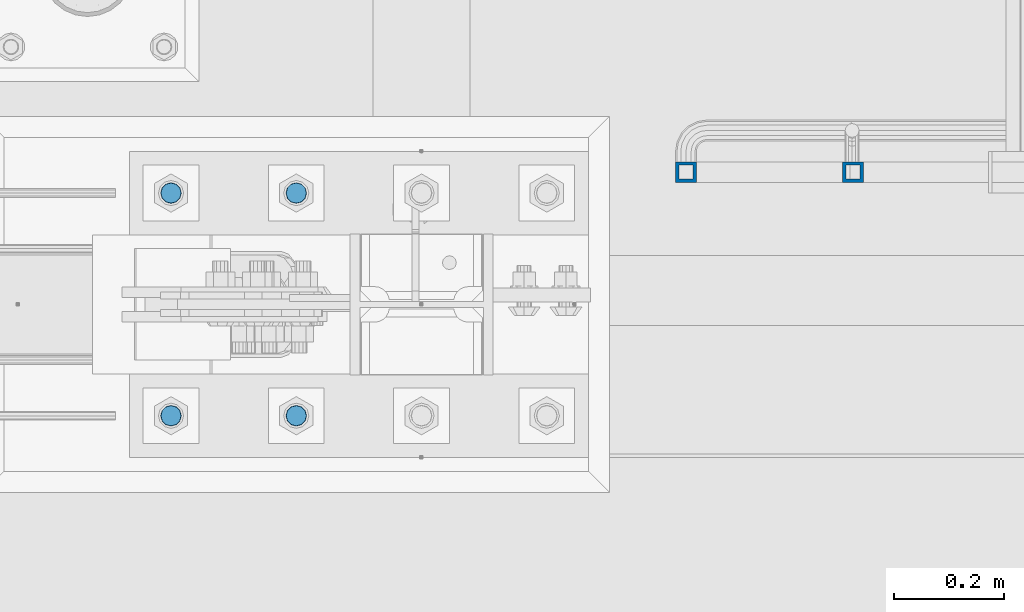
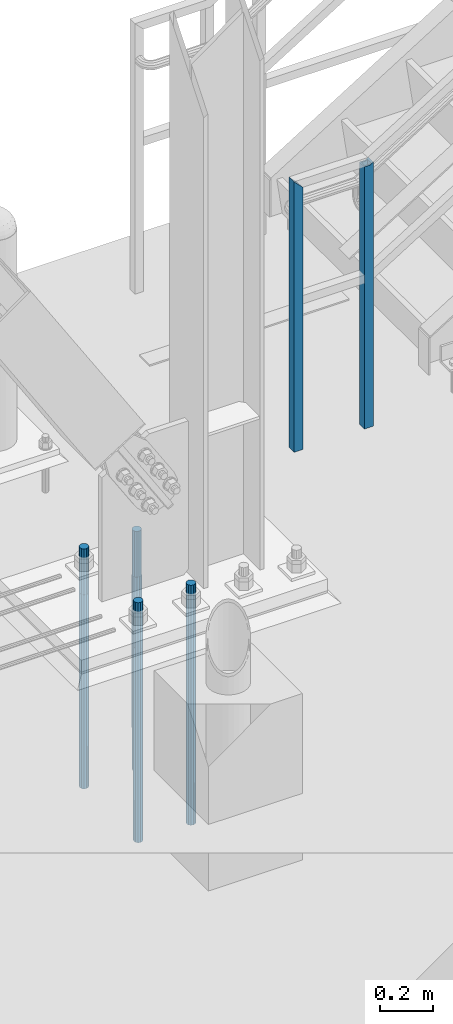
# One storey, part 1365 of 3843: 6 columns, 2 elements without a shape of their own.
"""IFC2X3 building model written with IfcOpenShell, lengths in millimetres."""

from ifc_helpers import new_model, si_unit, frame, origin_with_axes, place, context, subcontext, project, spatial, faceted_brep, material, type_object, element, aggregate, save


model = new_model("IFC2X3")

# Units and contexts
model_context = context("Model", 3, precision=1e-05, world=origin_with_axes())
body_context = subcontext(model_context, "Body", "Model", "MODEL_VIEW")
ifc_project = project(units=[si_unit("LENGTHUNIT", "METRE", prefix="MILLI"), si_unit("AREAUNIT", "SQUARE_METRE"), si_unit("VOLUMEUNIT", "CUBIC_METRE"), si_unit("MASSUNIT", "GRAM", prefix="KILO"), si_unit("TIMEUNIT", "SECOND"), si_unit("PLANEANGLEUNIT", "RADIAN"), si_unit("SOLIDANGLEUNIT", "STERADIAN"), si_unit("THERMODYNAMICTEMPERATUREUNIT", "DEGREE_CELSIUS"), si_unit("LUMINOUSINTENSITYUNIT", "LUMEN")], contexts=[model_context])

# Site, building, storey
site_placement = place(None, origin_with_axes())
site = spatial("IfcSite", under=ifc_project, at=site_placement, CompositionType="ELEMENT")
building_placement = place(site_placement, origin_with_axes())
building = spatial("IfcBuilding", under=site, at=building_placement, Name="Undefined", CompositionType="ELEMENT")
storey_placement = place(building_placement, origin_with_axes())
storey = spatial("IfcBuildingStorey", under=building, at=storey_placement, Name="Undefined", CompositionType="ELEMENT", Elevation=0.0)

# Assembly, columns
assembly_1_placement = place(storey_placement, origin_with_axes())
assembly_1 = element("IfcElementAssembly", 1, at=assembly_1_placement, inside=storey, Name="RAIL", AssemblyPlace="NOTDEFINED", PredefinedType="RIGID_FRAME")
ifc_material_1 = material()
column_type_1 = type_object("IfcColumnType", Name="HSS1-1/2X1-1/2X1/4", PredefinedType="NOTDEFINED")
column_1_placement = place(assembly_1_placement, frame((31267.4000000001, 89357.2000000455, 30480.0), z_axis=(-1.0, 0.0, 0.0), x_axis=(0.0, 0.0, 1.0)))
column_1 = element("IfcColumn", 2, at=column_1_placement, type_object=column_type_1, material=ifc_material_1, Name="POST", ObjectType="HSS1-1/2X1-1/2X1/4", context=body_context, shape_type="Brep", body=[
    faceted_brep([(1047.75000076629, -19.0499992350015, 19.0499992349942), (1047.75000076347, -19.0499992349796, -5.45142732938621), (1047.75000076347, -12.6999993299978, -5.45142732938621), (1047.75000076497, -12.6999993300014, 12.6999993299978), (1047.75000076497, 12.6999993300014, 12.6999993299978), (1047.75000076347, 12.6999993299978, -5.45142732938621), (1047.75000076347, 19.0499992350233, -5.45142732938621), (1047.75000076629, 19.0499992350015, 19.0499992349942), (1056.22703259967, -19.0499992349651, -19.0499992350015), (1056.22703259967, 19.0499992349942, -19.0499992350015), (1052.26859110094, 12.6999993299978, -12.6999993300014), (1052.26859110094, -12.6999993299978, -12.6999993300014), (-152.399999977541, 19.0499992350015, 19.0499992349942), (-152.399999977541, -19.0499992350015, 19.0499992349942), (-152.399999977541, -19.0499992350015, -19.0499992349942), (-152.399999977541, 19.0499992350015, -19.0499992349942), (-152.399999977541, 12.6999993299978, 12.6999993299978), (-152.399999977541, -12.6999993299978, 12.6999993299978), (-152.399999977541, -12.6999993299978, -12.6999993299978), (-152.399999977541, 12.6999993299978, -12.6999993299978)], [[[0, 1, 2, 3, 4, 5, 6, 7]], [[8, 9, 6, 5, 10, 11, 2, 1]], [[12, 13, 0, 7]], [[0, 13, 14, 8, 1]], [[14, 15, 9, 8]], [[15, 12, 7, 6, 9]], [[14, 13, 12, 15], [16, 17, 18, 19]], [[19, 18, 11, 10]], [[4, 16, 19, 10, 5]], [[17, 16, 4, 3]], [[18, 17, 3, 2, 11]]]),
])
column_2_placement = place(assembly_1_placement, frame((30962.6000000001, 89357.2000000455, 30480.0), z_axis=(-1.0, 0.0, 0.0), x_axis=(0.0, 0.0, 1.0)))
column_2 = element("IfcColumn", 3, at=column_2_placement, type_object=column_type_1, material=ifc_material_1, Name="POST", ObjectType="HSS1-1/2X1-1/2X1/4", context=body_context, shape_type="Brep", body=[
    faceted_brep([(-152.399999977541, 12.6999993299978, -12.6999993299978), (-152.399999977541, -12.6999993299978, -12.6999993299978), (1054.10000067001, -12.6999993300014, -12.6999993299978), (1054.10000067001, 12.6999993300014, -12.6999993299978), (-152.399999977541, -12.6999993299978, 12.6999993299978), (1079.49999933, -12.6999993300014, 12.6999993299978), (-152.399999977541, 12.6999993299978, 12.6999993299978), (1079.49999933, 12.6999993300014, 12.6999993299978), (-152.399999977541, 19.0499992350015, -19.0499992349942), (-152.399999977541, 19.0499992350015, 19.0499992349942), (1085.849999235, 19.0499992350015, 19.0499992350015), (1047.750000765, 19.0499992350015, -19.0499992350015), (-152.399999977541, -19.0499992350015, 19.0499992349942), (1085.849999235, -19.0499992350015, 19.0499992350015), (-152.399999977541, -19.0499992350015, -19.0499992349942), (1047.750000765, -19.0499992350015, -19.0499992350015)], [[[0, 1, 2, 3]], [[1, 4, 5, 2]], [[4, 6, 7, 5]], [[6, 0, 3, 7]], [[8, 9, 10, 11]], [[9, 12, 13, 10]], [[12, 14, 15, 13]], [[14, 8, 11, 15]], [[13, 15, 11, 10], [5, 7, 3, 2]], [[14, 12, 9, 8], [6, 4, 1, 0]]]),
])
aggregate(assembly_1, [column_1, column_2])

assembly_2_placement = place(storey_placement, origin_with_axes())
assembly_2 = element("IfcElementAssembly", 4, at=assembly_2_placement, inside=storey, Name="TEMPLATE", AssemblyPlace="NOTDEFINED", PredefinedType="RIGID_FRAME")
ifc_material_2 = material(Name="Undefined/F1554-GR.55")
column_type_2 = type_object("IfcColumnType", PredefinedType="NOTDEFINED")
column_3_placement = place(assembly_2_placement, frame((30251.4, 88912.7, 30022.8), z_axis=(1.0, 0.0, 0.0), x_axis=(0.0, 0.0, -1.0)))
column_3 = element("IfcColumn", 5, at=column_3_placement, type_object=column_type_2, material=ifc_material_2, Name="ANCHOR_ROD", context=body_context, shape_type="Brep", body=[
    faceted_brep([(-209.549999999999, -16.0214699700155, 9.25), (-209.549999999999, -9.25, 16.0214699700118), (-209.549999999999, 0.0, 18.5), (-209.549999999999, 9.25, 16.0214699700118), (-209.549999999999, 16.0214699700155, 9.25), (-209.549999999999, 18.5, 0.0), (-209.549999999999, 16.0214699700155, -9.25), (-209.549999999999, 9.25, -16.0214699700118), (-209.549999999999, 0.0, -18.5), (-209.549999999999, -9.25, -16.0214699700118), (-209.549999999999, -16.0214699700155, -9.25), (-209.549999999999, -18.5, 0.0), (0.0, 18.5, 0.0), (0.0, 16.0214699700118, -9.25), (0.0, 9.25, -16.0214699700155), (0.0, 0.0, -18.5), (0.0, -9.25, -16.0214699700155), (0.0, -16.0214699700118, -9.25), (0.0, -18.5, 0.0), (0.0, -16.0214699700118, 9.25), (0.0, -9.25, 16.0214699700155), (0.0, 0.0, 18.5), (0.0, 9.25, 16.0214699700155), (0.0, 16.0214699700118, 9.25), (0.0, -16.4977839420972, 9.52500000000146), (0.0, -9.52500000000146, 16.4977839420972), (0.0, 0.0, 19.0499989999989), (0.0, 9.52500000000146, 16.4977839420972), (0.0, 16.4977839420972, 9.52500000000146), (0.0, 19.0500000000029, 0.0), (0.0, 16.4977839420972, -9.52500000000146), (0.0, 9.52500000000146, -16.4977839420972), (0.0, 0.0, -19.0499989999989), (0.0, -9.52500000000146, -16.4977839420972), (0.0, -16.4977839420972, -9.52500000000146), (0.0, -19.0500000000029, 0.0), (698.5, -19.0499999999993, 0.0), (698.5, -16.4977839420935, 9.52499999999418), (698.5, -9.52500000000146, 16.4977839420899), (698.5, 0.0, 19.0500000000029), (698.5, 9.52500000000146, 16.4977839420899), (698.5, 16.4977839420935, 9.52499999999418), (698.5, 19.0499999999993, 0.0), (698.5, 16.4977839420935, -9.52499999999418), (698.5, 9.52500000000146, -16.4977839420899), (698.5, 0.0, -19.0500000000029), (698.5, -9.52500000000146, -16.4977839420899), (698.5, -16.4977839420935, -9.52499999999418), (698.5, -9.25, 16.0214699700155), (698.5, 0.0, 18.5), (698.5, 9.25, 16.0214699700155), (698.5, 16.0214699700118, 9.25), (698.5, 18.5, 0.0), (698.5, 16.0214699700118, -9.25), (698.5, 9.25, -16.0214699700155), (698.5, 0.0, -18.5), (698.5, -9.25, -16.0214699700155), (698.5, -16.0214699700118, -9.25), (698.5, -18.5, 0.0), (698.5, -16.0214699700118, 9.25), (889.0, -9.25, -16.0214699700155), (889.0, 0.0, -18.5), (889.0, 9.25, -16.0214699700155), (889.0, 16.0214699700118, -9.25), (889.0, 18.5, 0.0), (889.0, 16.0214699700118, 9.25), (889.0, 9.25, 16.0214699700155), (889.0, 0.0, 18.5), (889.0, -9.25, 16.0214699700155), (889.0, -16.0214699700118, 9.25), (889.0, -18.5, 0.0), (889.0, -16.0214699700118, -9.25)], [[[0, 1, 2, 3, 4, 5, 6, 7, 8, 9, 10, 11]], [[6, 5, 12, 13]], [[7, 6, 13, 14]], [[8, 7, 14, 15]], [[9, 8, 15, 16]], [[10, 9, 16, 17]], [[11, 10, 17, 18]], [[0, 11, 18, 19]], [[1, 0, 19, 20]], [[2, 1, 20, 21]], [[3, 2, 21, 22]], [[4, 3, 22, 23]], [[5, 4, 23, 12]], [[24, 25, 26, 27, 28, 29, 30, 31, 32, 33, 34, 35], [22, 21, 20, 19, 18, 17, 16, 15, 14, 13, 12, 23]], [[24, 35, 36, 37]], [[25, 24, 37, 38]], [[26, 25, 38, 39]], [[27, 26, 39, 40]], [[28, 27, 40, 41]], [[29, 28, 41, 42]], [[30, 29, 42, 43]], [[31, 30, 43, 44]], [[32, 31, 44, 45]], [[33, 32, 45, 46]], [[34, 33, 46, 47]], [[35, 34, 47, 36]], [[46, 45, 44, 43, 42, 41, 40, 39, 38, 37, 36, 47], [48, 49, 50, 51, 52, 53, 54, 55, 56, 57, 58, 59]], [[60, 61, 62, 63, 64, 65, 66, 67, 68, 69, 70, 71]], [[68, 67, 49, 48]], [[69, 68, 48, 59]], [[70, 69, 59, 58]], [[71, 70, 58, 57]], [[60, 71, 57, 56]], [[61, 60, 56, 55]], [[62, 61, 55, 54]], [[63, 62, 54, 53]], [[64, 63, 53, 52]], [[65, 64, 52, 51]], [[66, 65, 51, 50]], [[67, 66, 50, 49]]]),
])
column_4_placement = place(assembly_2_placement, frame((30251.4, 89319.1, 30022.8), z_axis=(-1.0, 0.0, 0.0), x_axis=(0.0, 0.0, -1.0)))
column_4 = element("IfcColumn", 6, at=column_4_placement, type_object=column_type_2, material=ifc_material_2, Name="ANCHOR_ROD", context=body_context, shape_type="Brep", body=[
    faceted_brep([(-209.549999999999, -16.0214699700155, 9.25), (-209.549999999999, -9.25, 16.0214699700118), (-209.549999999999, 0.0, 18.5), (-209.549999999999, 9.25, 16.0214699700118), (-209.549999999999, 16.0214699700155, 9.25), (-209.549999999999, 18.5, 0.0), (-209.549999999999, 16.0214699700155, -9.25), (-209.549999999999, 9.25, -16.0214699700118), (-209.549999999999, 0.0, -18.5), (-209.549999999999, -9.25, -16.0214699700118), (-209.549999999999, -16.0214699700155, -9.25), (-209.549999999999, -18.5, 0.0), (0.0, 18.5, 0.0), (0.0, 16.0214699700118, -9.25), (0.0, 9.25, -16.0214699700155), (0.0, 0.0, -18.5), (0.0, -9.25, -16.0214699700155), (0.0, -16.0214699700118, -9.25), (0.0, -18.5, 0.0), (0.0, -16.0214699700118, 9.25), (0.0, -9.25, 16.0214699700155), (0.0, 0.0, 18.5), (0.0, 9.25, 16.0214699700155), (0.0, 16.0214699700118, 9.25), (0.0, -16.4977839420972, 9.52500000000146), (0.0, -9.52500000000146, 16.4977839420972), (0.0, 0.0, 19.0499989999989), (0.0, 9.52500000000146, 16.4977839420972), (0.0, 16.4977839420972, 9.52500000000146), (0.0, 19.0500000000029, 0.0), (0.0, 16.4977839420972, -9.52500000000146), (0.0, 9.52500000000146, -16.4977839420972), (0.0, 0.0, -19.0499989999989), (0.0, -9.52500000000146, -16.4977839420972), (0.0, -16.4977839420972, -9.52500000000146), (0.0, -19.0500000000029, 0.0), (698.5, -19.0499999999993, 0.0), (698.5, -16.4977839420935, 9.52499999999418), (698.5, -9.52500000000146, 16.4977839420899), (698.5, 0.0, 19.0500000000029), (698.5, 9.52500000000146, 16.4977839420899), (698.5, 16.4977839420935, 9.52499999999418), (698.5, 19.0499999999993, 0.0), (698.5, 16.4977839420935, -9.52499999999418), (698.5, 9.52500000000146, -16.4977839420899), (698.5, 0.0, -19.0500000000029), (698.5, -9.52500000000146, -16.4977839420899), (698.5, -16.4977839420935, -9.52499999999418), (698.5, -9.25, 16.0214699700155), (698.5, 0.0, 18.5), (698.5, 9.25, 16.0214699700155), (698.5, 16.0214699700118, 9.25), (698.5, 18.5, 0.0), (698.5, 16.0214699700118, -9.25), (698.5, 9.25, -16.0214699700155), (698.5, 0.0, -18.5), (698.5, -9.25, -16.0214699700155), (698.5, -16.0214699700118, -9.25), (698.5, -18.5, 0.0), (698.5, -16.0214699700118, 9.25), (889.0, -9.25, -16.0214699700155), (889.0, 0.0, -18.5), (889.0, 9.25, -16.0214699700155), (889.0, 16.0214699700118, -9.25), (889.0, 18.5, 0.0), (889.0, 16.0214699700118, 9.25), (889.0, 9.25, 16.0214699700155), (889.0, 0.0, 18.5), (889.0, -9.25, 16.0214699700155), (889.0, -16.0214699700118, 9.25), (889.0, -18.5, 0.0), (889.0, -16.0214699700118, -9.25)], [[[0, 1, 2, 3, 4, 5, 6, 7, 8, 9, 10, 11]], [[6, 5, 12, 13]], [[7, 6, 13, 14]], [[8, 7, 14, 15]], [[9, 8, 15, 16]], [[10, 9, 16, 17]], [[11, 10, 17, 18]], [[0, 11, 18, 19]], [[1, 0, 19, 20]], [[2, 1, 20, 21]], [[3, 2, 21, 22]], [[4, 3, 22, 23]], [[5, 4, 23, 12]], [[24, 25, 26, 27, 28, 29, 30, 31, 32, 33, 34, 35], [22, 21, 20, 19, 18, 17, 16, 15, 14, 13, 12, 23]], [[24, 35, 36, 37]], [[25, 24, 37, 38]], [[26, 25, 38, 39]], [[27, 26, 39, 40]], [[28, 27, 40, 41]], [[29, 28, 41, 42]], [[30, 29, 42, 43]], [[31, 30, 43, 44]], [[32, 31, 44, 45]], [[33, 32, 45, 46]], [[34, 33, 46, 47]], [[35, 34, 47, 36]], [[46, 45, 44, 43, 42, 41, 40, 39, 38, 37, 36, 47], [48, 49, 50, 51, 52, 53, 54, 55, 56, 57, 58, 59]], [[60, 61, 62, 63, 64, 65, 66, 67, 68, 69, 70, 71]], [[68, 67, 49, 48]], [[69, 68, 48, 59]], [[70, 69, 59, 58]], [[71, 70, 58, 57]], [[60, 71, 57, 56]], [[61, 60, 56, 55]], [[62, 61, 55, 54]], [[63, 62, 54, 53]], [[64, 63, 53, 52]], [[65, 64, 52, 51]], [[66, 65, 51, 50]], [[67, 66, 50, 49]]]),
])
column_5_placement = place(assembly_2_placement, frame((30022.8, 88912.7, 30022.8), z_axis=(1.0, 0.0, 0.0), x_axis=(0.0, 0.0, -1.0)))
column_5 = element("IfcColumn", 7, at=column_5_placement, type_object=column_type_2, material=ifc_material_2, Name="ANCHOR_ROD", context=body_context, shape_type="Brep", body=[
    faceted_brep([(-209.549999999999, -16.0214699700155, 9.25), (-209.549999999999, -9.25, 16.0214699700118), (-209.549999999999, 0.0, 18.5), (-209.549999999999, 9.25, 16.0214699700118), (-209.549999999999, 16.0214699700155, 9.25), (-209.549999999999, 18.5, 0.0), (-209.549999999999, 16.0214699700155, -9.25), (-209.549999999999, 9.25, -16.0214699700118), (-209.549999999999, 0.0, -18.5), (-209.549999999999, -9.25, -16.0214699700118), (-209.549999999999, -16.0214699700155, -9.25), (-209.549999999999, -18.5, 0.0), (0.0, 18.5, 0.0), (0.0, 16.0214699700118, -9.25), (0.0, 9.25, -16.0214699700155), (0.0, 0.0, -18.5), (0.0, -9.25, -16.0214699700155), (0.0, -16.0214699700118, -9.25), (0.0, -18.5, 0.0), (0.0, -16.0214699700118, 9.25), (0.0, -9.25, 16.0214699700155), (0.0, 0.0, 18.5), (0.0, 9.25, 16.0214699700155), (0.0, 16.0214699700118, 9.25), (0.0, -16.4977839420972, 9.52500000000146), (0.0, -9.52500000000146, 16.4977839420972), (0.0, 0.0, 19.0499989999989), (0.0, 9.52500000000146, 16.4977839420972), (0.0, 16.4977839420972, 9.52500000000146), (0.0, 19.0500000000029, 0.0), (0.0, 16.4977839420972, -9.52500000000146), (0.0, 9.52500000000146, -16.4977839420972), (0.0, 0.0, -19.0499989999989), (0.0, -9.52500000000146, -16.4977839420972), (0.0, -16.4977839420972, -9.52500000000146), (0.0, -19.0500000000029, 0.0), (698.5, -19.0499999999993, 0.0), (698.5, -16.4977839420935, 9.52499999999418), (698.5, -9.52500000000146, 16.4977839420899), (698.5, 0.0, 19.0500000000029), (698.5, 9.52500000000146, 16.4977839420899), (698.5, 16.4977839420935, 9.52499999999418), (698.5, 19.0499999999993, 0.0), (698.5, 16.4977839420935, -9.52499999999418), (698.5, 9.52500000000146, -16.4977839420899), (698.5, 0.0, -19.0500000000029), (698.5, -9.52500000000146, -16.4977839420899), (698.5, -16.4977839420935, -9.52499999999418), (698.5, -9.25, 16.0214699700155), (698.5, 0.0, 18.5), (698.5, 9.25, 16.0214699700155), (698.5, 16.0214699700118, 9.25), (698.5, 18.5, 0.0), (698.5, 16.0214699700118, -9.25), (698.5, 9.25, -16.0214699700155), (698.5, 0.0, -18.5), (698.5, -9.25, -16.0214699700155), (698.5, -16.0214699700118, -9.25), (698.5, -18.5, 0.0), (698.5, -16.0214699700118, 9.25), (889.0, -9.25, -16.0214699700155), (889.0, 0.0, -18.5), (889.0, 9.25, -16.0214699700155), (889.0, 16.0214699700118, -9.25), (889.0, 18.5, 0.0), (889.0, 16.0214699700118, 9.25), (889.0, 9.25, 16.0214699700155), (889.0, 0.0, 18.5), (889.0, -9.25, 16.0214699700155), (889.0, -16.0214699700118, 9.25), (889.0, -18.5, 0.0), (889.0, -16.0214699700118, -9.25)], [[[0, 1, 2, 3, 4, 5, 6, 7, 8, 9, 10, 11]], [[6, 5, 12, 13]], [[7, 6, 13, 14]], [[8, 7, 14, 15]], [[9, 8, 15, 16]], [[10, 9, 16, 17]], [[11, 10, 17, 18]], [[0, 11, 18, 19]], [[1, 0, 19, 20]], [[2, 1, 20, 21]], [[3, 2, 21, 22]], [[4, 3, 22, 23]], [[5, 4, 23, 12]], [[24, 25, 26, 27, 28, 29, 30, 31, 32, 33, 34, 35], [22, 21, 20, 19, 18, 17, 16, 15, 14, 13, 12, 23]], [[24, 35, 36, 37]], [[25, 24, 37, 38]], [[26, 25, 38, 39]], [[27, 26, 39, 40]], [[28, 27, 40, 41]], [[29, 28, 41, 42]], [[30, 29, 42, 43]], [[31, 30, 43, 44]], [[32, 31, 44, 45]], [[33, 32, 45, 46]], [[34, 33, 46, 47]], [[35, 34, 47, 36]], [[46, 45, 44, 43, 42, 41, 40, 39, 38, 37, 36, 47], [48, 49, 50, 51, 52, 53, 54, 55, 56, 57, 58, 59]], [[60, 61, 62, 63, 64, 65, 66, 67, 68, 69, 70, 71]], [[68, 67, 49, 48]], [[69, 68, 48, 59]], [[70, 69, 59, 58]], [[71, 70, 58, 57]], [[60, 71, 57, 56]], [[61, 60, 56, 55]], [[62, 61, 55, 54]], [[63, 62, 54, 53]], [[64, 63, 53, 52]], [[65, 64, 52, 51]], [[66, 65, 51, 50]], [[67, 66, 50, 49]]]),
])
column_6_placement = place(assembly_2_placement, frame((30022.8, 89319.1, 30022.8), z_axis=(-1.0, 0.0, 0.0), x_axis=(0.0, 0.0, -1.0)))
column_6 = element("IfcColumn", 8, at=column_6_placement, type_object=column_type_2, material=ifc_material_2, Name="ANCHOR_ROD", context=body_context, shape_type="Brep", body=[
    faceted_brep([(-209.549999999999, -16.0214699700155, 9.25), (-209.549999999999, -9.25, 16.0214699700118), (-209.549999999999, 0.0, 18.5), (-209.549999999999, 9.25, 16.0214699700118), (-209.549999999999, 16.0214699700155, 9.25), (-209.549999999999, 18.5, 0.0), (-209.549999999999, 16.0214699700155, -9.25), (-209.549999999999, 9.25, -16.0214699700118), (-209.549999999999, 0.0, -18.5), (-209.549999999999, -9.25, -16.0214699700118), (-209.549999999999, -16.0214699700155, -9.25), (-209.549999999999, -18.5, 0.0), (0.0, 18.5, 0.0), (0.0, 16.0214699700118, -9.25), (0.0, 9.25, -16.0214699700155), (0.0, 0.0, -18.5), (0.0, -9.25, -16.0214699700155), (0.0, -16.0214699700118, -9.25), (0.0, -18.5, 0.0), (0.0, -16.0214699700118, 9.25), (0.0, -9.25, 16.0214699700155), (0.0, 0.0, 18.5), (0.0, 9.25, 16.0214699700155), (0.0, 16.0214699700118, 9.25), (0.0, -16.4977839420972, 9.52500000000146), (0.0, -9.52500000000146, 16.4977839420972), (0.0, 0.0, 19.0499989999989), (0.0, 9.52500000000146, 16.4977839420972), (0.0, 16.4977839420972, 9.52500000000146), (0.0, 19.0500000000029, 0.0), (0.0, 16.4977839420972, -9.52500000000146), (0.0, 9.52500000000146, -16.4977839420972), (0.0, 0.0, -19.0499989999989), (0.0, -9.52500000000146, -16.4977839420972), (0.0, -16.4977839420972, -9.52500000000146), (0.0, -19.0500000000029, 0.0), (698.5, -19.0499999999993, 0.0), (698.5, -16.4977839420935, 9.52499999999418), (698.5, -9.52500000000146, 16.4977839420899), (698.5, 0.0, 19.0500000000029), (698.5, 9.52500000000146, 16.4977839420899), (698.5, 16.4977839420935, 9.52499999999418), (698.5, 19.0499999999993, 0.0), (698.5, 16.4977839420935, -9.52499999999418), (698.5, 9.52500000000146, -16.4977839420899), (698.5, 0.0, -19.0500000000029), (698.5, -9.52500000000146, -16.4977839420899), (698.5, -16.4977839420935, -9.52499999999418), (698.5, -9.25, 16.0214699700155), (698.5, 0.0, 18.5), (698.5, 9.25, 16.0214699700155), (698.5, 16.0214699700118, 9.25), (698.5, 18.5, 0.0), (698.5, 16.0214699700118, -9.25), (698.5, 9.25, -16.0214699700155), (698.5, 0.0, -18.5), (698.5, -9.25, -16.0214699700155), (698.5, -16.0214699700118, -9.25), (698.5, -18.5, 0.0), (698.5, -16.0214699700118, 9.25), (889.0, -9.25, -16.0214699700155), (889.0, 0.0, -18.5), (889.0, 9.25, -16.0214699700155), (889.0, 16.0214699700118, -9.25), (889.0, 18.5, 0.0), (889.0, 16.0214699700118, 9.25), (889.0, 9.25, 16.0214699700155), (889.0, 0.0, 18.5), (889.0, -9.25, 16.0214699700155), (889.0, -16.0214699700118, 9.25), (889.0, -18.5, 0.0), (889.0, -16.0214699700118, -9.25)], [[[0, 1, 2, 3, 4, 5, 6, 7, 8, 9, 10, 11]], [[6, 5, 12, 13]], [[7, 6, 13, 14]], [[8, 7, 14, 15]], [[9, 8, 15, 16]], [[10, 9, 16, 17]], [[11, 10, 17, 18]], [[0, 11, 18, 19]], [[1, 0, 19, 20]], [[2, 1, 20, 21]], [[3, 2, 21, 22]], [[4, 3, 22, 23]], [[5, 4, 23, 12]], [[24, 25, 26, 27, 28, 29, 30, 31, 32, 33, 34, 35], [22, 21, 20, 19, 18, 17, 16, 15, 14, 13, 12, 23]], [[24, 35, 36, 37]], [[25, 24, 37, 38]], [[26, 25, 38, 39]], [[27, 26, 39, 40]], [[28, 27, 40, 41]], [[29, 28, 41, 42]], [[30, 29, 42, 43]], [[31, 30, 43, 44]], [[32, 31, 44, 45]], [[33, 32, 45, 46]], [[34, 33, 46, 47]], [[35, 34, 47, 36]], [[46, 45, 44, 43, 42, 41, 40, 39, 38, 37, 36, 47], [48, 49, 50, 51, 52, 53, 54, 55, 56, 57, 58, 59]], [[60, 61, 62, 63, 64, 65, 66, 67, 68, 69, 70, 71]], [[68, 67, 49, 48]], [[69, 68, 48, 59]], [[70, 69, 59, 58]], [[71, 70, 58, 57]], [[60, 71, 57, 56]], [[61, 60, 56, 55]], [[62, 61, 55, 54]], [[63, 62, 54, 53]], [[64, 63, 53, 52]], [[65, 64, 52, 51]], [[66, 65, 51, 50]], [[67, 66, 50, 49]]]),
])
aggregate(assembly_2, [column_3, column_4, column_5, column_6])

save(model, "model.ifc")
